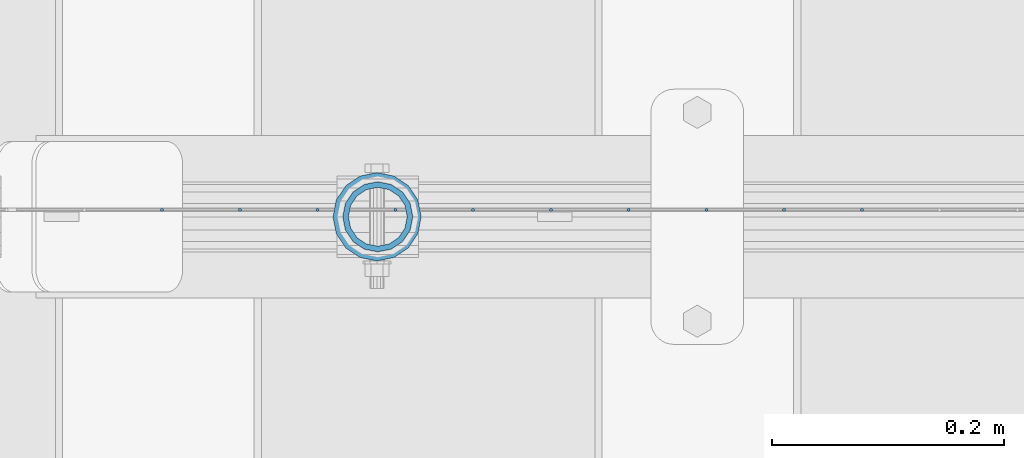
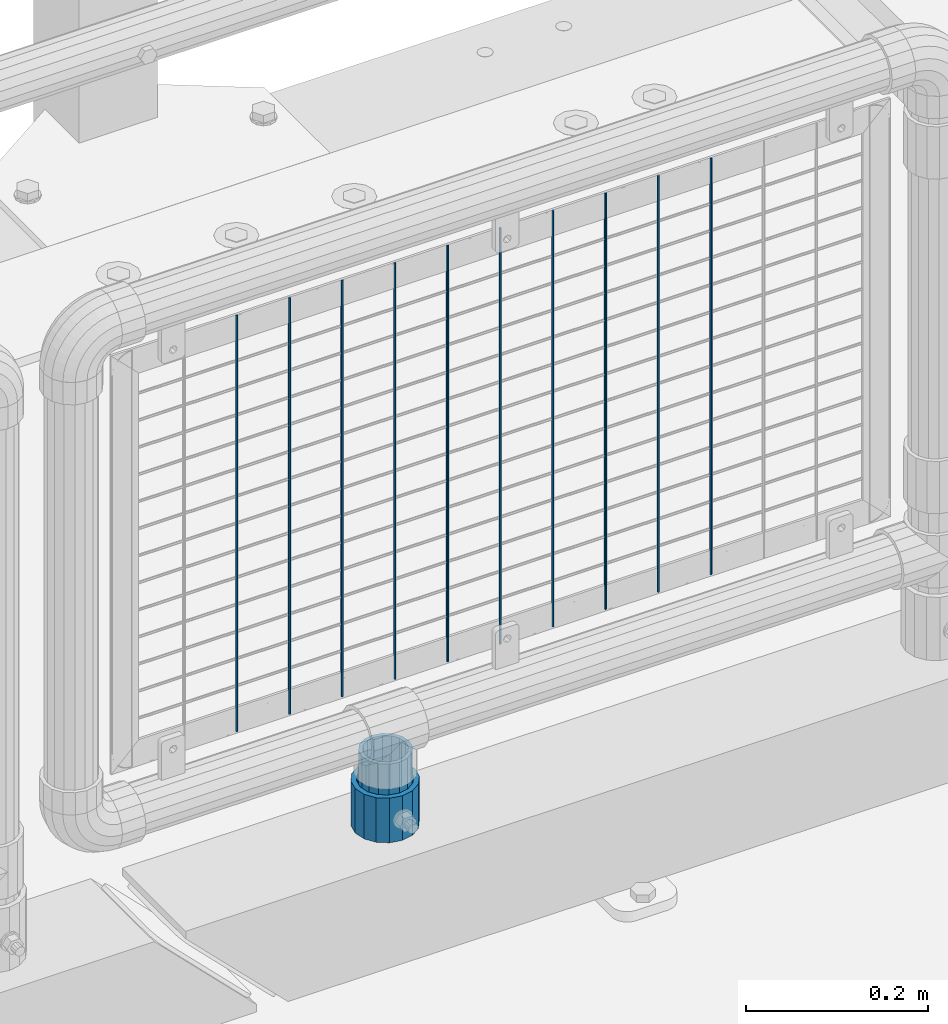
# One storey, part 86 of 208: 12 columns.
"""IFC2X3 building model written with IfcOpenShell, lengths in millimetres."""

from ifc_helpers import new_model, si_unit, frame, origin_with_axes, place, context, subcontext, project, spatial, faceted_brep, material, type_object, element, save


model = new_model("IFC2X3")

# Units and contexts
model_context = context("Model", 3, precision=1e-05, world=origin_with_axes())
body_context = subcontext(model_context, "Body", "Model", "MODEL_VIEW")
ifc_project = project(units=[si_unit("LENGTHUNIT", "METRE", prefix="MILLI"), si_unit("AREAUNIT", "SQUARE_METRE"), si_unit("VOLUMEUNIT", "CUBIC_METRE"), si_unit("MASSUNIT", "GRAM", prefix="KILO"), si_unit("TIMEUNIT", "SECOND"), si_unit("PLANEANGLEUNIT", "RADIAN"), si_unit("SOLIDANGLEUNIT", "STERADIAN"), si_unit("THERMODYNAMICTEMPERATUREUNIT", "DEGREE_CELSIUS"), si_unit("LUMINOUSINTENSITYUNIT", "LUMEN")], contexts=[model_context])

# Site, building, storey
site_placement = place(None, origin_with_axes())
site = spatial("IfcSite", under=ifc_project, at=site_placement, CompositionType="ELEMENT")
building_placement = place(site_placement, origin_with_axes())
building = spatial("IfcBuilding", under=site, at=building_placement, Name="Standard", CompositionType="ELEMENT")
storey_placement = place(building_placement, origin_with_axes())
storey = spatial("IfcBuildingStorey", under=building, at=storey_placement, Name="Undefined", CompositionType="ELEMENT", Elevation=0.0)

# Columns
ifc_material_1 = material()
column_type_1 = type_object("IfcColumnType", PredefinedType="NOTDEFINED")
column_1_placement = place(storey_placement, frame((-26929.0, 4664.5, 168.019999999998), z_axis=(0.0, 1.0, 0.0), x_axis=(0.0, 0.0, 1.0)))
element("IfcColumn", 1, at=column_1_placement, inside=storey, type_object=column_type_1, material=ifc_material_1, context=body_context, shape_type="Brep", body=[
    faceted_brep([(0.0, -31.75, 0.0), (0.0, -29.3331751572332, 12.1501989775916), (60.0, -29.3331751572332, 12.1501989775916), (60.0, -31.75, 0.0), (0.0, -22.4506403026717, 22.4506403026726), (60.0, -22.4506403026717, 22.4506403026726), (0.0, -12.1501989775934, 29.3331751572332), (60.0, -12.1501989775934, 29.3331751572332), (0.0, 0.0, 31.75), (60.0, 0.0, 31.75), (0.0, 12.1501989775934, 29.3331751572332), (60.0, 12.1501989775934, 29.3331751572332), (0.0, 22.4506403026717, 22.4506403026726), (60.0, 22.4506403026717, 22.4506403026726), (0.0, 29.3331751572332, 12.1501989775916), (60.0, 29.3331751572332, 12.1501989775916), (0.0, 31.75, 0.0), (60.0, 31.75, 0.0), (0.0, 29.3331751572332, -12.1501989775916), (60.0, 29.3331751572332, -12.1501989775916), (0.0, 22.4506403026717, -22.4506403026726), (60.0, 22.4506403026717, -22.4506403026726), (0.0, 12.1501989775934, -29.3331751572332), (60.0, 12.1501989775934, -29.3331751572332), (0.0, 0.0, -31.75), (60.0, 0.0, -31.75), (0.0, -12.1501989775934, -29.3331751572332), (60.0, -12.1501989775934, -29.3331751572332), (0.0, -22.4506403026717, -22.4506403026726), (60.0, -22.4506403026717, -22.4506403026726), (0.0, -29.3331751572332, -12.1501989775916), (60.0, -29.3331751572332, -12.1501989775916), (0.0, -38.0499999999993, 0.0), (0.0, -35.1536162120537, -14.5611046014919), (60.0, -35.1536162120537, -14.5611046014919), (60.0, -38.0499999999993, 0.0), (0.0, -26.9054130241493, -26.9054130241484), (60.0, -26.9054130241493, -26.9054130241484), (0.0, -14.5611046014928, -35.1536162120547), (60.0, -14.5611046014928, -35.1536162120547), (0.0, 0.0, -38.0500000000002), (60.0, 0.0, -38.0500000000002), (0.0, 14.5611046014928, -35.1536162120547), (60.0, 14.5611046014928, -35.1536162120547), (0.0, 26.9054130241493, -26.9054130241484), (60.0, 26.9054130241493, -26.9054130241484), (0.0, 35.1536162120537, -14.5611046014919), (60.0, 35.1536162120537, -14.5611046014919), (0.0, 38.0499999999993, 0.0), (60.0, 38.0499999999993, 0.0), (0.0, 35.1536162120537, 14.5611046014919), (60.0, 35.1536162120537, 14.5611046014919), (0.0, 26.9054130241493, 26.9054130241484), (60.0, 26.9054130241493, 26.9054130241484), (0.0, 14.5611046014928, 35.1536162120547), (60.0, 14.5611046014928, 35.1536162120547), (0.0, 0.0, 38.0500000000002), (60.0, 0.0, 38.0500000000002), (0.0, -14.5611046014928, 35.1536162120547), (60.0, -14.5611046014928, 35.1536162120547), (0.0, -26.9054130241493, 26.9054130241484), (60.0, -26.9054130241493, 26.9054130241484), (0.0, -35.1536162120537, 14.5611046014919), (60.0, -35.1536162120537, 14.5611046014919)], [[[0, 1, 2, 3]], [[1, 4, 5, 2]], [[4, 6, 7, 5]], [[6, 8, 9, 7]], [[8, 10, 11, 9]], [[10, 12, 13, 11]], [[12, 14, 15, 13]], [[14, 16, 17, 15]], [[16, 18, 19, 17]], [[18, 20, 21, 19]], [[20, 22, 23, 21]], [[22, 24, 25, 23]], [[24, 26, 27, 25]], [[26, 28, 29, 27]], [[28, 30, 31, 29]], [[30, 0, 3, 31]], [[32, 33, 34, 35]], [[33, 36, 37, 34]], [[36, 38, 39, 37]], [[38, 40, 41, 39]], [[40, 42, 43, 41]], [[42, 44, 45, 43]], [[44, 46, 47, 45]], [[46, 48, 49, 47]], [[48, 50, 51, 49]], [[50, 52, 53, 51]], [[52, 54, 55, 53]], [[54, 56, 57, 55]], [[56, 58, 59, 57]], [[58, 60, 61, 59]], [[60, 62, 63, 61]], [[62, 32, 35, 63]], [[37, 39, 41, 43, 45, 47, 49, 51, 53, 55, 57, 59, 61, 63, 35, 34], [5, 7, 9, 11, 13, 15, 17, 19, 21, 23, 25, 27, 29, 31, 3, 2]], [[62, 60, 58, 56, 54, 52, 50, 48, 46, 44, 42, 40, 38, 36, 33, 32], [30, 28, 26, 24, 22, 20, 18, 16, 14, 12, 10, 8, 6, 4, 1, 0]]]),
])
column_type_2 = type_object("IfcColumnType", PredefinedType="NOTDEFINED")
column_2_placement = place(storey_placement, frame((-26928.39, 4664.5, 168.02), z_axis=(-1.0, 0.0, 0.0), x_axis=(0.0, 0.0, 1.0)))
element("IfcColumn", 2, at=column_2_placement, inside=storey, type_object=column_type_2, material=ifc_material_1, context=body_context, shape_type="Brep", body=[
    faceted_brep([(0.0, -25.3500000000004, 0.0), (0.0, -23.4203461491616, 9.70102501045403), (100.0, -23.4203461491616, 9.70102501045403), (100.0, -25.3500000000004, 0.0), (0.0, -17.9251569030794, 17.9251569030785), (100.0, -17.9251569030794, 17.9251569030785), (0.0, -9.70102501045494, 23.4203461491597), (100.0, -9.70102501045494, 23.4203461491597), (0.0, 0.0, 25.3499999999985), (100.0, 0.0, 25.3499999999985), (0.0, 9.70102501045494, 23.4203461491597), (100.0, 9.70102501045494, 23.4203461491597), (0.0, 17.9251569030794, 17.9251569030785), (100.0, 17.9251569030794, 17.9251569030785), (0.0, 23.4203461491616, 9.70102501045403), (100.0, 23.4203461491616, 9.70102501045403), (0.0, 25.3500000000004, 0.0), (100.0, 25.3500000000004, 0.0), (0.0, 23.4203461491616, -9.70102501045403), (100.0, 23.4203461491616, -9.70102501045403), (0.0, 17.9251569030794, -17.9251569030785), (100.0, 17.9251569030794, -17.9251569030785), (0.0, 9.70102501045494, -23.4203461491597), (100.0, 9.70102501045494, -23.4203461491597), (0.0, 0.0, -25.3499999999985), (100.0, 0.0, -25.3499999999985), (0.0, -9.70102501045494, -23.4203461491597), (100.0, -9.70102501045494, -23.4203461491597), (0.0, -17.9251569030794, -17.9251569030785), (100.0, -17.9251569030794, -17.9251569030785), (0.0, -23.4203461491616, -9.70102501045403), (100.0, -23.4203461491616, -9.70102501045403), (0.0, -30.1499999999996, 0.0), (0.0, -27.8549679052148, -11.5379054858058), (100.0, -27.8549679052148, -11.5379054858058), (100.0, -30.1499999999996, 0.0), (0.0, -21.3192694527743, -21.3192694527752), (100.0, -21.3192694527743, -21.3192694527752), (0.0, -11.5379054858076, -27.8549679052157), (100.0, -11.5379054858076, -27.8549679052157), (0.0, 0.0, -30.1500000000015), (100.0, 0.0, -30.1500000000015), (0.0, 11.5379054858076, -27.8549679052157), (100.0, 11.5379054858076, -27.8549679052157), (0.0, 21.3192694527743, -21.3192694527752), (100.0, 21.3192694527743, -21.3192694527752), (0.0, 27.8549679052157, -11.5379054858058), (100.0, 27.8549679052157, -11.5379054858058), (0.0, 30.1499999999996, 0.0), (100.0, 30.1499999999996, 0.0), (0.0, 27.8549679052157, 11.5379054858058), (100.0, 27.8549679052157, 11.5379054858058), (0.0, 21.3192694527743, 21.3192694527752), (100.0, 21.3192694527743, 21.3192694527752), (0.0, 11.5379054858076, 27.8549679052157), (100.0, 11.5379054858076, 27.8549679052157), (0.0, 0.0, 30.1500000000015), (100.0, 0.0, 30.1500000000015), (0.0, -11.5379054858076, 27.8549679052157), (100.0, -11.5379054858076, 27.8549679052157), (0.0, -21.3192694527743, 21.3192694527752), (100.0, -21.3192694527743, 21.3192694527752), (0.0, -27.8549679052157, 11.5379054858058), (100.0, -27.8549679052157, 11.5379054858058)], [[[0, 1, 2, 3]], [[1, 4, 5, 2]], [[4, 6, 7, 5]], [[6, 8, 9, 7]], [[8, 10, 11, 9]], [[10, 12, 13, 11]], [[12, 14, 15, 13]], [[14, 16, 17, 15]], [[16, 18, 19, 17]], [[18, 20, 21, 19]], [[20, 22, 23, 21]], [[22, 24, 25, 23]], [[24, 26, 27, 25]], [[26, 28, 29, 27]], [[28, 30, 31, 29]], [[30, 0, 3, 31]], [[32, 33, 34, 35]], [[33, 36, 37, 34]], [[36, 38, 39, 37]], [[38, 40, 41, 39]], [[40, 42, 43, 41]], [[42, 44, 45, 43]], [[44, 46, 47, 45]], [[46, 48, 49, 47]], [[48, 50, 51, 49]], [[50, 52, 53, 51]], [[52, 54, 55, 53]], [[54, 56, 57, 55]], [[56, 58, 59, 57]], [[58, 60, 61, 59]], [[60, 62, 63, 61]], [[62, 32, 35, 63]], [[37, 39, 41, 43, 45, 47, 49, 51, 53, 55, 57, 59, 61, 63, 35, 34], [5, 7, 9, 11, 13, 15, 17, 19, 21, 23, 25, 27, 29, 31, 3, 2]], [[62, 60, 58, 56, 54, 52, 50, 48, 46, 44, 42, 40, 38, 36, 33, 32], [30, 28, 26, 24, 22, 20, 18, 16, 14, 12, 10, 8, 6, 4, 1, 0]]]),
])
ifc_material_2 = material(Name="Misc_Undefined")
column_type_3 = type_object("IfcColumnType", Name="D3", PredefinedType="NOTDEFINED")
for number, where, z_axis, x_axis in (
    (3, (-26511.0819999999, 4670.49982672734, 353.02), (-1.0, 0.0, 0.0), (0.0, 0.0, 1.0)),
    (4, (-26578.1099999999, 4670.49984093615, 353.02), (-1.0, 0.0, 0.0), (0.0, 0.0, 1.0)),
    (5, (-26645.1379999999, 4670.49985514497, 353.02), (-1.0, 0.0, 0.0), (0.0, 0.0, 1.0)),
    (6, (-26712.1659999999, 4670.49986935379, 353.02), (-1.0, 0.0, 0.0), (0.0, 0.0, 1.0)),
    (7, (-26913.2499999999, 4670.49991198024, 353.02), (-1.0, 0.0, 0.0), (0.0, 0.0, 1.0)),
    (8, (-26980.2779999999, 4670.49992618905, 353.02), (-1.0, 0.0, 0.0), (0.0, 0.0, 1.0)),
    (9, (-27047.306, 4670.49994039787, 353.02), (-1.0, 0.0, 0.0), (0.0, 0.0, 1.0)),
    (10, (-26846.2219999999, 4670.49989777142, 353.02), (-1.0, 0.0, 0.0), (0.0, 0.0, 1.0)),
    (11, (-27114.334, 4670.49995460668, 353.02), (-1.0, 0.0, 0.0), (0.0, 0.0, 1.0)),
    (12, (-26779.1939999999, 4670.4998835626, 353.02), (-1.0, 0.0, 0.0), (0.0, 0.0, 1.0)),
):
    element("IfcColumn", number, at=place(storey_placement, frame(where, z_axis=z_axis, x_axis=x_axis)), inside=storey, type_object=column_type_3, material=ifc_material_2, ObjectType="D3", context=body_context, shape_type="Brep", body=[
        faceted_brep([(0.0, -1.49999999999909, 3.63797880709171e-12), (-7.27595761418343e-12, -0.749999999999091, -1.29903810567669), (560.0, -0.75, -1.29903810567703), (560.0, -1.5, 0.0), (-3.63797880709171e-12, 0.750000000000909, -1.29903810567669), (560.0, 0.75, -1.29903810567703), (0.0, 1.50000000000182, 3.63797880709171e-12), (560.0, 1.5, 0.0), (-3.63797880709171e-12, 0.750000000000909, 1.29903810567669), (560.0, 0.75, 1.29903810567703), (-7.27595761418343e-12, -0.749999999999091, 1.29903810567669), (560.0, -0.75, 1.29903810567703)], [[[0, 1, 2, 3]], [[1, 4, 5, 2]], [[4, 6, 7, 5]], [[6, 8, 9, 7]], [[8, 10, 11, 9]], [[10, 0, 3, 11]], [[5, 7, 9, 11, 3, 2]], [[10, 8, 6, 4, 1, 0]]]),
    ])

save(model, "model.ifc")
